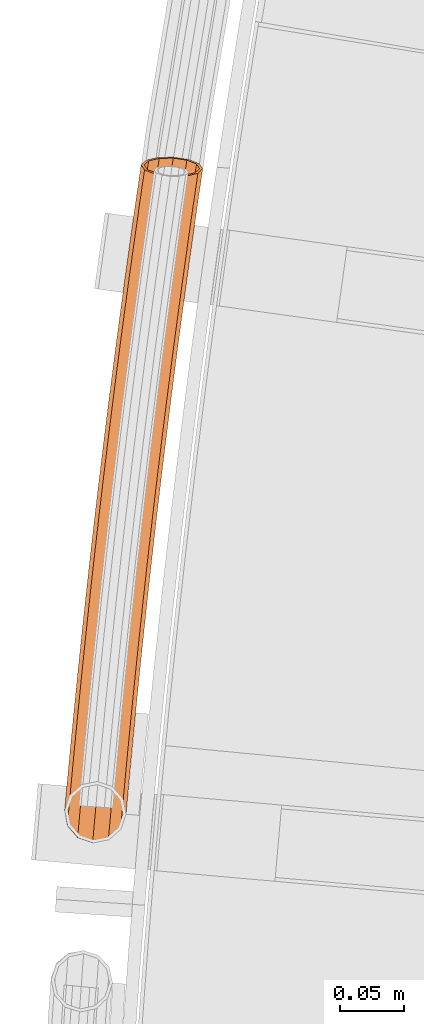
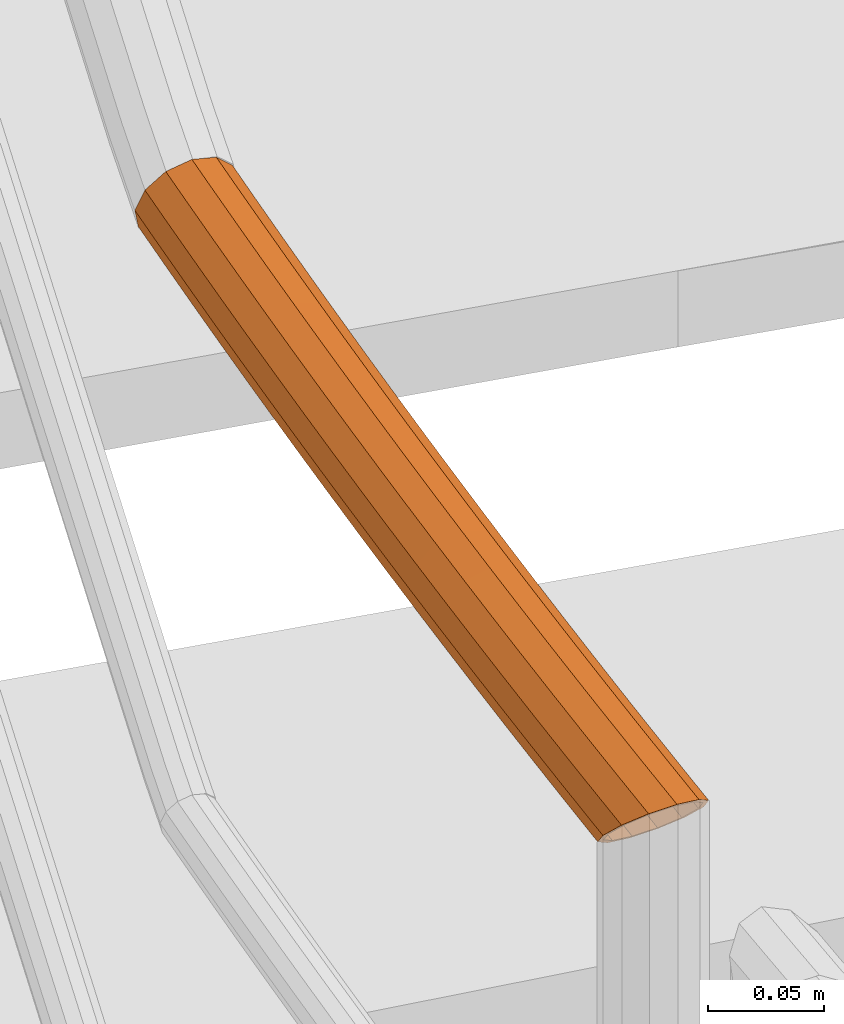
# One storey, part 58 of 126: 1 proxy.
"""IFC2X3 building model written with IfcOpenShell, lengths in millimetres."""

import ifcopenshell
import ifcopenshell.guid

model = None  # the IFC model being written
_history = None  # IfcOwnerHistory: only IFC2X3 demands one
_inside = {}  # id of a spatial element -> (the spatial element, [elements in it])
_under = {}  # id of a project, library or spatial element -> (it, [spatial elements below it])
_declared = {}  # id of a project -> (the project, [libraries it declares])
_typed = {}  # id of a type object -> (the type object, [elements of that type])
_made_of = {}  # id of a material, layer set ... -> (it, [elements and type objects made of it])


def new_model(schema):
    """Start an empty IFC model of exactly this schema.

    Asked for "IFC4X3", IfcOpenShell would pick the latest addendum, in which some entities
    have other attributes; the version numbers below select the first issue.
    IFC2X3 requires an IfcOwnerHistory on every rooted entity: one is made here for all.
    """
    global model, _history
    if schema == "IFC4X3":
        model = ifcopenshell.file(schema_version=(4, 3, 0, 0))
    else:
        model = ifcopenshell.file(schema=schema)
    _inside.clear()
    _under.clear()
    _declared.clear()
    _typed.clear()
    _made_of.clear()
    _history = None
    if model.schema == "IFC2X3":
        org = make("IfcOrganization", Name="unknown")
        user = make(
            "IfcPersonAndOrganization",
            ThePerson=make("IfcPerson", FamilyName="unknown"),
            TheOrganization=org,
        )
        app = make(
            "IfcApplication",
            ApplicationDeveloper=org,
            Version="unknown",
            ApplicationFullName="unknown",
            ApplicationIdentifier="unknown",
        )
        _history = make(
            "IfcOwnerHistory",
            OwningUser=user,
            OwningApplication=app,
            ChangeAction="ADDED",
            CreationDate=0,
        )
    return model


def make(cls, **values):
    """One entity of the class cls with the attributes given. An attribute that is None is left unset."""
    return model.create_entity(
        cls, **{name: value for name, value in values.items() if value is not None}
    )


def rooted(cls, **values):
    """An entity with a GlobalId (a new one), such as an element, a storey or a relation."""
    return make(cls, GlobalId=ifcopenshell.guid.new(), OwnerHistory=_history, **values)


def si_unit(unit_type, name, prefix=None):
    """IfcSIUnit, for example si_unit("LENGTHUNIT", "METRE", prefix="MILLI")."""
    return make("IfcSIUnit", UnitType=unit_type, Prefix=prefix, Name=name)


def assignment(units):
    """IfcUnitAssignment: the units of a project."""
    return None if units is None else make("IfcUnitAssignment", Units=units)


def point(xyz):
    """IfcCartesianPoint."""
    return None if xyz is None else make("IfcCartesianPoint", Coordinates=xyz)


def direction(xyz):
    """IfcDirection."""
    return None if xyz is None else make("IfcDirection", DirectionRatios=xyz)


def frame(location, z_axis=None, x_axis=None):
    """IfcAxis2Placement3D, a coordinate frame: its origin and axes. An axis left out is left unset."""
    return make(
        "IfcAxis2Placement3D",
        Location=point(location),
        Axis=direction(z_axis),
        RefDirection=direction(x_axis),
    )


def origin():
    """The frame at (0, 0, 0) with its axes left unset."""
    return frame((0.0, 0.0, 0.0))


def origin_with_axes():
    """The frame at (0, 0, 0) with the z axis (0, 0, 1) and the x axis (1, 0, 0) written out."""
    return frame((0.0, 0.0, 0.0), z_axis=(0.0, 0.0, 1.0), x_axis=(1.0, 0.0, 0.0))


def place(relative_to, where):
    """IfcLocalPlacement: puts the frame where relative to a parent placement (None: the world)."""
    return make(
        "IfcLocalPlacement", PlacementRelTo=relative_to, RelativePlacement=where
    )


def context(
    kind, dimensions, precision=None, world=None, true_north=None, identifier=None
):
    """IfcGeometricRepresentationContext, for example the 3D "Model" context."""
    return make(
        "IfcGeometricRepresentationContext",
        ContextIdentifier=identifier,
        ContextType=kind,
        CoordinateSpaceDimension=dimensions,
        Precision=precision,
        WorldCoordinateSystem=world,
        TrueNorth=true_north,
    )


def project(units=None, contexts=None):
    """IfcProject with its units and contexts."""
    return rooted(
        "IfcProject",
        Name="project",
        RepresentationContexts=contexts,
        UnitsInContext=assignment(units),
    )


def spatial(cls, under=None, at=None, **own):
    """A site, building, storey or space (cls), placed at a placement, below another one or the project."""
    s = rooted(cls, ObjectPlacement=at, **own)
    if under is not None:
        _under.setdefault(under.id(), (under, []))[1].append(s)
    return s


def faces_of(points, faces, orient=None, outer=None):
    """IfcFace entities. A face is a list of loops; a loop is a list of indices into points, from 0.

    orient and outer hold one flag for each loop. By default every Orientation is true, the
    first loop of a face is its IfcFaceOuterBound and the others are IfcFaceBound.
    """
    made = []
    for i, loops in enumerate(faces):
        bounds = []
        for j, loop in enumerate(loops):
            is_outer = j == 0 if outer is None else outer[i][j]
            bounds.append(
                make(
                    "IfcFaceOuterBound" if is_outer else "IfcFaceBound",
                    Bound=make("IfcPolyLoop", Polygon=[points[k] for k in loop]),
                    Orientation=True if orient is None else orient[i][j],
                )
            )
        made.append(make("IfcFace", Bounds=bounds))
    return made


def faceted_brep(points, faces, orient=None, outer=None, voids=None):
    """IfcFacetedBrep: a solid bounded by flat faces; with voids (closed shells), ...WithVoids."""
    shared = [point(p) for p in points]
    hull = make("IfcClosedShell", CfsFaces=faces_of(shared, faces, orient, outer))
    if voids is None:
        return make("IfcFacetedBrep", Outer=hull)
    return make(
        "IfcFacetedBrepWithVoids",
        Outer=hull,
        Voids=[
            make(cls, CfsFaces=faces_of(shared, fs, o, b)) for cls, fs, o, b in voids
        ],
    )


def shape(context_of_items, identifier, shape_type, items):
    """IfcShapeRepresentation: the items that make up one representation, for example the "Body"."""
    return make(
        "IfcShapeRepresentation",
        ContextOfItems=context_of_items,
        RepresentationIdentifier=identifier,
        RepresentationType=shape_type,
        Items=items,
    )


def material(Name=None, Category=None):
    """IfcMaterial."""
    return make("IfcMaterial", Name=Name, Category=Category)


def made_of(thing, what):
    """Note that an element or type object is made of a material, layer set ...; save() writes the relation."""
    if what is not None:
        _made_of.setdefault(what.id(), (what, []))[1].append(thing)
    return thing


def element(
    cls,
    number,
    at=None,
    inside=None,
    cuts=None,
    type_object=None,
    material=None,
    context=None,
    identifier="Body",
    shape_type=None,
    held_by="IfcProductDefinitionShape",
    body=None,
    shapes=None,
    **own,
):
    """One element of the class cls, such as IfcWall. Its Tag is "e" and its number.

    at: its placement. inside: the storey or other place that contains it. cuts: it is an
    opening in that element (IfcRelVoidsElement). A single representation is given by context,
    identifier, shape_type and body (its items); several are given by shapes. held_by: the class
    of the entity that holds the representations. save() writes the other relations.
    """
    e = rooted(cls, Tag="e%d" % number, ObjectPlacement=at, **own)
    if body is not None:
        shapes = [shape(context, identifier, shape_type, body)]
    if shapes is not None:
        e.Representation = make(held_by, Representations=shapes)
    if inside is not None:
        _inside.setdefault(inside.id(), (inside, []))[1].append(e)
    if cuts is not None:
        rooted(
            "IfcRelVoidsElement", RelatingBuildingElement=cuts, RelatedOpeningElement=e
        )
    if type_object is not None:
        _typed.setdefault(type_object.id(), (type_object, []))[1].append(e)
    return made_of(e, material)


def aggregate(whole, parts):
    """IfcRelAggregates: a whole, such as a stair, and the parts it consists of."""
    return rooted("IfcRelAggregates", RelatingObject=whole, RelatedObjects=parts)


def save(model, path):
    """Write the relations noted so far, then the file.

    IfcRelAggregates (storeys below a building ...), IfcRelContainedInSpatialStructure (elements
    in a storey), IfcRelDefinesByType, IfcRelAssociatesMaterial and IfcRelDeclares: one each for
    every whole, place, type object, material and project.
    """
    for whole, parts in _under.values():
        aggregate(whole, parts)
    for where, things in _inside.values():
        rooted(
            "IfcRelContainedInSpatialStructure",
            RelatedElements=things,
            RelatingStructure=where,
        )
    for kind, things in _typed.values():
        rooted("IfcRelDefinesByType", RelatedObjects=things, RelatingType=kind)
    for what, things in _made_of.values():
        rooted("IfcRelAssociatesMaterial", RelatedObjects=things, RelatingMaterial=what)
    for by, libraries in _declared.values():
        rooted("IfcRelDeclares", RelatingContext=by, RelatedDefinitions=libraries)
    model.write(path)


model = new_model("IFC2X3")

# Units and contexts
context_of_model_1 = context(None, 3, precision=0.1, world=origin())
context_of_model_2 = context(None, 3, precision=0.1, world=origin())
ifc_project = project(units=[si_unit("LENGTHUNIT", "METRE", prefix="MILLI"), si_unit("AREAUNIT", "SQUARE_METRE", prefix="CENTI"), si_unit("VOLUMEUNIT", "CUBIC_METRE", prefix="CENTI"), si_unit("MASSUNIT", "GRAM", prefix="KILO")], contexts=[context_of_model_1, context_of_model_2])

# Site, building, storey
site_placement = place(None, origin_with_axes())
site = spatial("IfcSite", under=ifc_project, at=site_placement, CompositionType="ELEMENT")
building_placement = place(site_placement, origin_with_axes())
building = spatial("IfcBuilding", under=site, at=building_placement, CompositionType="ELEMENT")
storey_placement = place(building_placement, origin_with_axes())
storey = spatial("IfcBuildingStorey", under=building, at=storey_placement, CompositionType="ELEMENT")

# Proxy
ifc_material = material(Name="S235JRG2")
proxy_placement = place(storey_placement, origin_with_axes())
element("IfcBuildingElementProxy", 1, at=proxy_placement, inside=storey, material=ifc_material, Name="HANDLAUF", context=context_of_model_2, shape_type="Brep", body=[
    faceted_brep([(-812.9843, 8779.5754, 6639.3145), (-813.4282, 8774.4188, 6639.3145), (-807.944, 8779.1326, 6634.2548), (-825.013, 8780.632, 6642.55), (-825.758, 8771.9781, 6642.55), (-837.0417, 8781.6886, 6639.3145), (-837.5326, 8775.986, 6639.3145), (-842.8746, 8782.2009, 6633.4592), (-835.7965, 8781.5792, 6637.1494), (-836.0993, 8778.0624, 6637.1494), (-839.3936, 8781.8952, 6633.5385), (-825.013, 8780.632, 6640.05), (-825.5435, 8774.4694, 6640.05), (-814.2296, 8779.6848, 6637.1494), (-814.4901, 8776.6574, 6637.1494), (-811.2705, 8779.4248, 6634.179), (-846.3017, 8813.6469, 6618.4), (-843.0796, 8813.3526, 6606.325), (-843.4312, 8809.4287, 6606.325), (-847.7387, 8797.6082, 6618.4), (-839.2575, 8813.0034, 6602.487), (-801.424, 8809.5469, 6606.325), (-801.6778, 8806.714, 6606.325), (-804.3318, 8809.8126, 6603.4051), (-798.2019, 8809.2526, 6618.4), (-799.5261, 8794.4736, 6618.4), (-801.424, 8809.5469, 6630.475), (-803.8337, 8782.6531, 6630.475), (-810.2268, 8810.3512, 6639.3145), (-822.2518, 8811.4498, 6642.55), (-834.2767, 8812.5483, 6639.3145), (-845.587, 8785.3678, 6630.475), (-843.0796, 8813.3526, 6630.475), (-843.812, 8813.4195, 6618.4), (-840.9235, 8813.1556, 6629.225), (-843.3143, 8786.4727, 6629.225), (-845.2432, 8797.446, 6618.4), (-833.0319, 8812.4346, 6637.1494), (-822.2518, 8811.4498, 6640.05), (-811.4717, 8810.4649, 6637.1494), (-803.5801, 8809.7439, 6629.225), (-805.8832, 8784.039, 6629.225), (-800.6915, 8809.48, 6618.4), (-802.0216, 8794.6358, 6618.4), (-803.5801, 8809.7439, 6607.575), (-803.9505, 8805.6091, 6607.575), (-807.8241, 8810.1317, 6603.3133), (-840.9235, 8813.1556, 6607.575), (-841.3816, 8808.0428, 6607.575), (-835.9434, 8812.7006, 6602.5741), (-843.425, 8844.5388, 6618.4), (-840.204, 8844.2332, 6606.325), (-831.404, 8843.3983, 6597.4855), (-833.8007, 8817.6607, 6597.4855), (-819.383, 8842.2577, 6594.25), (-821.4463, 8820.0997, 6594.25), (-807.3619, 8841.1171, 6597.4855), (-809.6922, 8816.0932, 6597.4855), (-798.5619, 8840.2822, 6606.325), (-795.3409, 8839.9766, 6618.4), (-798.5619, 8840.2822, 6630.475), (-807.3619, 8841.1171, 6639.3145), (-819.383, 8842.2577, 6642.55), (-831.404, 8843.3983, 6639.3145), (-840.204, 8844.2332, 6630.475), (-840.9362, 8844.3027, 6618.4), (-838.0486, 8844.0287, 6629.225), (-830.1596, 8843.2802, 6637.1494), (-819.383, 8842.2577, 6640.05), (-808.6064, 8841.2352, 6637.1494), (-800.7173, 8840.4867, 6629.225), (-797.8297, 8840.2127, 6618.4), (-800.7173, 8840.4867, 6607.575), (-811.1408, 8814.0178, 6599.6506), (-808.6064, 8841.2352, 6599.6506), (-819.383, 8842.2577, 6596.75), (-821.6782, 8817.6095, 6596.75), (-830.1596, 8843.2802, 6599.6506), (-832.7536, 8815.423, 6599.6506), (-838.0486, 8844.0287, 6607.575), (-840.4406, 8875.4205, 6618.4), (-837.2207, 8875.1036, 6606.325), (-828.4236, 8874.238, 6597.4855), (-816.4066, 8873.0554, 6594.25), (-804.3897, 8871.8729, 6597.4855), (-795.5926, 8871.0073, 6606.325), (-792.3727, 8870.6904, 6618.4), (-795.5926, 8871.0073, 6630.475), (-804.3897, 8871.8729, 6639.3145), (-816.4066, 8873.0554, 6642.55), (-828.4236, 8874.238, 6639.3145), (-837.2207, 8875.1036, 6630.475), (-837.9526, 8875.1756, 6618.4), (-835.066, 8874.8916, 6629.225), (-827.1796, 8874.1155, 6637.1494), (-816.4066, 8873.0554, 6640.05), (-805.6337, 8871.9953, 6637.1494), (-797.7473, 8871.2193, 6629.225), (-794.8607, 8870.9353, 6618.4), (-797.7473, 8871.2193, 6607.575), (-805.6337, 8871.9953, 6599.6506), (-816.4066, 8873.0554, 6596.75), (-827.1796, 8874.1155, 6599.6506), (-835.066, 8874.8916, 6607.575), (-837.3484, 8906.2915, 6618.4), (-834.1296, 8905.9634, 6606.325), (-825.3356, 8905.0671, 6597.4855), (-813.3228, 8903.8426, 6594.25), (-801.31, 8902.6182, 6597.4855), (-792.5161, 8901.7218, 6606.325), (-789.2973, 8901.3937, 6618.4), (-792.5161, 8901.7218, 6630.475), (-801.31, 8902.6182, 6639.3145), (-813.3228, 8903.8426, 6642.55), (-825.3356, 8905.0671, 6639.3145), (-834.1296, 8905.9634, 6630.475), (-834.8613, 8906.038, 6618.4), (-831.9756, 8905.7439, 6629.225), (-824.092, 8904.9403, 6637.1494), (-813.3228, 8903.8426, 6640.05), (-802.5536, 8902.7449, 6637.1494), (-794.67, 8901.9413, 6629.225), (-791.7844, 8901.6472, 6618.4), (-794.67, 8901.9413, 6607.575), (-802.5536, 8902.7449, 6599.6506), (-813.3228, 8903.8426, 6596.75), (-824.092, 8904.9403, 6599.6506), (-831.9756, 8905.7439, 6607.575), (-834.1484, 8937.1516, 6618.4), (-830.9308, 8936.8123, 6606.325), (-822.14, 8935.8852, 6597.4855), (-810.1315, 8934.6188, 6594.25), (-798.1231, 8933.3525, 6597.4855), (-789.3323, 8932.4254, 6606.325), (-786.1147, 8932.0861, 6618.4), (-789.3323, 8932.4254, 6630.475), (-798.1231, 8933.3525, 6639.3145), (-810.1315, 8934.6188, 6642.55), (-822.14, 8935.8852, 6639.3145), (-830.9308, 8936.8123, 6630.475), (-831.6622, 8936.8894, 6618.4), (-828.7776, 8936.5852, 6629.225), (-820.8969, 8935.7541, 6637.1494), (-810.1315, 8934.6188, 6640.05), (-799.3662, 8933.4835, 6637.1494), (-791.4855, 8932.6525, 6629.225), (-788.6009, 8932.3483, 6618.4), (-791.4855, 8932.6525, 6607.575), (-799.3662, 8933.4835, 6599.6506), (-810.1315, 8934.6188, 6596.75), (-820.8969, 8935.7541, 6599.6506), (-828.7776, 8936.5852, 6607.575), (-830.8407, 8968.0003, 6618.4), (-827.6243, 8967.6497, 6606.325), (-818.8368, 8966.692, 6597.4855), (-806.8329, 8965.3837, 6594.25), (-794.8289, 8964.0754, 6597.4855), (-786.0414, 8963.1177, 6606.325), (-782.825, 8962.7671, 6618.4), (-786.0414, 8963.1177, 6630.475), (-794.8289, 8964.0754, 6639.3145), (-806.8329, 8965.3837, 6642.55), (-818.8368, 8966.692, 6639.3145), (-827.6243, 8967.6497, 6630.475), (-828.3554, 8967.7294, 6618.4), (-825.472, 8967.4152, 6629.225), (-817.5942, 8966.5566, 6637.1494), (-806.8329, 8965.3837, 6640.05), (-796.0716, 8964.2109, 6637.1494), (-788.1938, 8963.3523, 6629.225), (-785.3103, 8963.038, 6618.4), (-788.1938, 8963.3523, 6607.575), (-796.0716, 8964.2109, 6599.6506), (-806.8329, 8965.3837, 6596.75), (-817.5942, 8966.5566, 6599.6506), (-825.472, 8967.4152, 6607.575), (-827.4254, 8998.8373, 6618.4), (-824.2102, 8998.4755, 6606.325), (-815.4261, 8997.4871, 6597.4855), (-803.4268, 8996.1369, 6594.25), (-791.4275, 8994.7867, 6597.4855), (-782.6434, 8993.7983, 6606.325), (-779.4282, 8993.4365, 6618.4), (-782.6434, 8993.7983, 6630.475), (-791.4275, 8994.7867, 6639.3145), (-803.4268, 8996.1369, 6642.55), (-815.4261, 8997.4871, 6639.3145), (-824.2102, 8998.4755, 6630.475), (-824.9411, 8998.5577, 6618.4), (-822.0587, 8998.2334, 6629.225), (-814.1839, 8997.3473, 6637.1494), (-803.4268, 8996.1369, 6640.05), (-792.6697, 8994.9265, 6637.1494), (-784.7949, 8994.0404, 6629.225), (-781.9126, 8993.7161, 6618.4), (-784.7949, 8994.0404, 6607.575), (-792.6697, 8994.9265, 6599.6506), (-803.4268, 8996.1369, 6596.75), (-814.1839, 8997.3473, 6599.6506), (-822.0587, 8998.2334, 6607.575), (-823.9025, 9029.6621, 6618.4), (-820.6885, 9029.2891, 6606.325), (-811.9079, 9028.2701, 6597.4855), (-799.9134, 9026.878, 6594.25), (-787.9189, 9025.486, 6597.4855), (-779.1383, 9024.4669, 6606.325), (-775.9244, 9024.0939, 6618.4), (-779.1383, 9024.4669, 6630.475), (-787.9189, 9025.486, 6639.3145), (-799.9134, 9026.878, 6642.55), (-811.9079, 9028.2701, 6639.3145), (-820.6885, 9029.2891, 6630.475), (-821.4191, 9029.3739, 6618.4), (-818.5379, 9029.0395, 6629.225), (-810.6663, 9028.126, 6637.1494), (-799.9134, 9026.878, 6640.05), (-789.1606, 9025.6301, 6637.1494), (-781.289, 9024.7165, 6629.225), (-778.4078, 9024.3821, 6618.4), (-781.289, 9024.7165, 6607.575), (-789.1606, 9025.6301, 6599.6506), (-799.9134, 9026.878, 6596.75), (-810.6663, 9028.126, 6599.6506), (-818.5379, 9029.0395, 6607.575), (-820.2719, 9060.4745, 6618.4), (-817.0593, 9060.0903, 6606.325), (-808.2824, 9059.0406, 6597.4855), (-796.2928, 9057.6067, 6594.25), (-784.3032, 9056.1728, 6597.4855), (-775.5262, 9055.1231, 6606.325), (-772.3136, 9054.7388, 6618.4), (-775.5262, 9055.1231, 6630.475), (-784.3032, 9056.1728, 6639.3145), (-796.2928, 9057.6067, 6642.55), (-808.2824, 9059.0406, 6639.3145), (-817.0593, 9060.0903, 6630.475), (-817.7896, 9060.1776, 6618.4), (-814.9096, 9059.8332, 6629.225), (-807.0412, 9058.8921, 6637.1494), (-796.2928, 9057.6067, 6640.05), (-785.5444, 9056.3212, 6637.1494), (-777.676, 9055.3802, 6629.225), (-774.7959, 9055.0357, 6618.4), (-777.676, 9055.3802, 6607.575), (-785.5444, 9056.3212, 6599.6506), (-796.2928, 9057.6067, 6596.75), (-807.0412, 9058.8921, 6599.6506), (-814.9096, 9059.8332, 6607.575), (-816.5339, 9091.274, 6618.4), (-813.3226, 9090.8786, 6606.325), (-804.5494, 9089.7983, 6597.4855), (-792.5649, 9088.3225, 6594.25), (-780.5804, 9086.8467, 6597.4855), (-771.8071, 9085.7664, 6606.325), (-768.5959, 9085.371, 6618.4), (-771.8071, 9085.7664, 6630.475), (-780.5804, 9086.8467, 6639.3145), (-792.5649, 9088.3225, 6642.55), (-804.5494, 9089.7983, 6639.3145), (-813.3226, 9090.8786, 6630.475), (-814.0526, 9090.9685, 6618.4), (-811.1738, 9090.614, 6629.225), (-803.3087, 9089.6455, 6637.1494), (-792.5649, 9088.3225, 6640.05), (-781.821, 9086.9995, 6637.1494), (-773.9559, 9086.031, 6629.225), (-771.0771, 9085.6765, 6618.4), (-773.9559, 9086.031, 6607.575), (-781.821, 9086.9995, 6599.6506), (-792.5649, 9088.3225, 6596.75), (-803.3087, 9089.6455, 6599.6506), (-811.1738, 9090.614, 6607.575), (-812.6883, 9122.0603, 6618.4), (-809.4785, 9121.6537, 6606.325), (-800.709, 9120.5427, 6597.4855), (-788.7298, 9119.0251, 6594.25), (-776.7505, 9117.5076, 6597.4855), (-767.9811, 9116.3966, 6606.325), (-764.7712, 9115.99, 6618.4), (-767.9811, 9116.3966, 6630.475), (-776.7505, 9117.5076, 6639.3145), (-788.7298, 9119.0251, 6642.55), (-800.709, 9120.5427, 6639.3145), (-809.4785, 9121.6537, 6630.475), (-810.2081, 9121.7461, 6618.4), (-807.3306, 9121.3816, 6629.225), (-799.469, 9120.3856, 6637.1494), (-788.7298, 9119.0251, 6640.05), (-777.9906, 9117.6646, 6637.1494), (-770.129, 9116.6687, 6629.225), (-767.2514, 9116.3042, 6618.4), (-770.129, 9116.6687, 6607.575), (-777.9906, 9117.6646, 6599.6506), (-788.7298, 9119.0251, 6596.75), (-799.469, 9120.3856, 6599.6506), (-807.3306, 9121.3816, 6607.575), (-808.7353, 9152.833, 6618.4), (-805.5269, 9152.4151, 6606.325), (-796.7614, 9151.2736, 6597.4855), (-784.7875, 9149.7142, 6594.25), (-772.8136, 9148.1548, 6597.4855), (-764.0481, 9147.0133, 6606.325), (-760.8397, 9146.5954, 6618.4), (-764.0481, 9147.0133, 6630.475), (-772.8136, 9148.1548, 6639.3145), (-784.7875, 9149.7142, 6642.55), (-796.7614, 9151.2736, 6639.3145), (-805.5269, 9152.4151, 6630.475), (-806.2563, 9152.5101, 6618.4), (-803.38, 9152.1355, 6629.225), (-795.5219, 9151.1122, 6637.1494), (-784.7875, 9149.7142, 6640.05), (-774.0532, 9148.3162, 6637.1494), (-766.1951, 9147.2929, 6629.225), (-763.3188, 9146.9183, 6618.4), (-766.1951, 9147.2929, 6607.575), (-774.0532, 9148.3162, 6599.6506), (-784.7875, 9149.7142, 6596.75), (-795.5219, 9151.1122, 6599.6506), (-803.38, 9152.1355, 6607.575), (-804.675, 9183.5917, 6618.4), (-801.468, 9183.1626, 6606.325), (-792.7066, 9181.9905, 6597.4855), (-780.7382, 9180.3893, 6594.25), (-768.7698, 9178.7881, 6597.4855), (-760.0083, 9177.616, 6606.325), (-756.8014, 9177.1869, 6618.4), (-760.0083, 9177.616, 6630.475), (-768.7698, 9178.7881, 6639.3145), (-780.7382, 9180.3893, 6642.55), (-792.7066, 9181.9905, 6639.3145), (-801.468, 9183.1626, 6630.475), (-802.197, 9183.2601, 6618.4), (-799.3221, 9182.8755, 6629.225), (-791.4676, 9181.8247, 6637.1494), (-780.7382, 9180.3893, 6640.05), (-770.0088, 9178.9539, 6637.1494), (-762.1543, 9177.9031, 6629.225), (-759.2793, 9177.5185, 6618.4), (-762.1543, 9177.9031, 6607.575), (-770.0088, 9178.9539, 6599.6506), (-780.7382, 9180.3893, 6596.75), (-791.4676, 9181.8247, 6599.6506), (-799.3221, 9182.8755, 6607.575), (-800.5072, 9214.336, 6618.4), (-797.3018, 9213.8958, 6606.325), (-788.5445, 9212.693, 6597.4855), (-776.5818, 9211.0501, 6594.25), (-764.6191, 9209.4071, 6597.4855), (-755.8617, 9208.2044, 6606.325), (-752.6563, 9207.7642, 6618.4), (-755.8617, 9208.2044, 6630.475), (-764.6191, 9209.4071, 6639.3145), (-776.5818, 9211.0501, 6642.55), (-788.5445, 9212.693, 6639.3145), (-797.3018, 9213.8958, 6630.475), (-798.0305, 9213.9958, 6618.4), (-795.1569, 9213.6012, 6629.225), (-787.3061, 9212.523, 6637.1494), (-776.5818, 9211.0501, 6640.05), (-765.8574, 9209.5772, 6637.1494), (-758.0067, 9208.499, 6629.225), (-755.1331, 9208.1044, 6618.4), (-758.0067, 9208.499, 6607.575), (-765.8574, 9209.5772, 6599.6506), (-776.5818, 9211.0501, 6596.75), (-787.3061, 9212.523, 6599.6506), (-795.1569, 9213.6012, 6607.575), (-796.2322, 9245.0656, 6618.4), (-793.0284, 9244.6142, 6606.325), (-784.2753, 9243.3809, 6597.4855), (-772.3184, 9241.6962, 6594.25), (-760.3615, 9240.0115, 6597.4855), (-751.6084, 9238.7782, 6606.325), (-748.4045, 9238.3268, 6618.4), (-751.6084, 9238.7782, 6630.475), (-760.3615, 9240.0115, 6639.3145), (-772.3184, 9241.6962, 6642.55), (-784.2753, 9243.3809, 6639.3145), (-793.0284, 9244.6142, 6630.475), (-793.7567, 9244.7168, 6618.4), (-790.8845, 9244.3121, 6629.225), (-783.0375, 9243.2065, 6637.1494), (-772.3184, 9241.6962, 6640.05), (-761.5992, 9240.1859, 6637.1494), (-753.7523, 9239.0803, 6629.225), (-750.8801, 9238.6756, 6618.4), (-753.7523, 9239.0803, 6607.575), (-761.5992, 9240.1859, 6599.6506), (-772.3184, 9241.6962, 6596.75), (-783.0375, 9243.2065, 6599.6506), (-790.8845, 9244.3121, 6607.575), (-791.85, 9275.78, 6618.4), (-788.6477, 9275.3175, 6606.325), (-779.899, 9274.0536, 6597.4855), (-767.948, 9272.3272, 6594.25), (-755.9971, 9270.6008, 6597.4855), (-747.2484, 9269.337, 6606.325), (-744.0461, 9268.8744, 6618.4), (-747.2484, 9269.337, 6630.475), (-755.9971, 9270.6008, 6639.3145), (-767.948, 9272.3272, 6642.55), (-779.899, 9274.0536, 6639.3145), (-788.6477, 9275.3175, 6630.475), (-789.3756, 9275.4226, 6618.4), (-786.5049, 9275.0079, 6629.225), (-778.6618, 9273.8749, 6637.1494), (-767.948, 9272.3272, 6640.05), (-757.2342, 9270.7795, 6637.1494), (-749.3912, 9269.6465, 6629.225), (-746.5204, 9269.2318, 6618.4), (-749.3912, 9269.6465, 6607.575), (-757.2342, 9270.7795, 6599.6506), (-767.948, 9272.3272, 6596.75), (-778.6618, 9273.8749, 6599.6506), (-786.5049, 9275.0079, 6607.575), (-787.7121, 9304.0751, 6618.4), (-785.4627, 9306.1981, 6611.2402), (-784.1599, 9306.0053, 6606.325), (-775.4156, 9304.7109, 6597.4855), (-763.4708, 9302.9428, 6594.25), (-751.5259, 9301.1747, 6597.4855), (-742.7817, 9299.8803, 6606.325), (-739.5811, 9299.4065, 6618.4), (-740.7847, 9299.5847, 6622.9409), (-743.1516, 9297.3507, 6630.475), (-752.4069, 9295.1507, 6639.3145), (-764.6439, 9294.9209, 6642.55), (-776.5839, 9296.7227, 6639.3145), (-785.0274, 9300.0733, 6630.475), (-785.2093, 9303.9123, 6618.4), (-782.8025, 9300.3249, 6629.225), (-775.233, 9297.3211, 6637.1494), (-764.5291, 9295.7058, 6640.05), (-753.5588, 9295.9119, 6637.1494), (-745.2617, 9297.8841, 6629.225), (-743.0972, 9299.927, 6622.3353), (-742.0541, 9299.7726, 6618.4), (-744.9234, 9300.1973, 6607.575), (-752.7624, 9301.3577, 6599.6506), (-763.4708, 9302.9428, 6596.75), (-774.1791, 9304.5279, 6599.6506), (-782.0182, 9305.6882, 6607.575), (-783.1502, 9305.8558, 6611.8458), (-783.9127, 9307.6552, 6606.325), (-774.6451, 9309.8543, 6597.4855), (-762.401, 9310.0837, 6594.25), (-750.4612, 9308.282, 6597.4855), (-742.0249, 9304.9318, 6606.325), (-739.3527, 9300.9309, 6618.4), (-741.8562, 9301.0936, 6618.4), (-744.2518, 9304.6804, 6607.575), (-751.8148, 9307.6837, 6599.6506), (-762.5186, 9309.299, 6596.75), (-773.4952, 9309.0933, 6599.6506), (-781.8034, 9307.1219, 6607.575)], [[[0, 1, 2]], [[0, 3, 4, 1]], [[3, 5, 6, 4]], [[5, 7, 6]], [[8, 9, 10]], [[8, 11, 12, 9]], [[11, 13, 14, 12]], [[13, 15, 14]], [[16, 17, 18, 19]], [[17, 20, 18]], [[21, 22, 23]], [[21, 24, 25, 22]], [[24, 26, 27, 25]], [[0, 2, 27, 26, 28]], [[0, 28, 29, 3]], [[3, 29, 30, 5]], [[31, 7, 5, 30, 32]], [[16, 19, 31, 32]], [[33, 34, 35, 36]], [[35, 34, 37, 8, 10]], [[8, 37, 38, 11]], [[11, 38, 39, 13]], [[13, 39, 40, 41, 15]], [[40, 42, 43, 41]], [[42, 44, 45, 43]], [[44, 46, 45]], [[47, 48, 49]], [[33, 36, 48, 47]], [[16, 50, 51, 17]], [[17, 51, 52, 53, 20]], [[52, 54, 55, 53]], [[54, 56, 57, 55]], [[57, 56, 58, 21, 23]], [[21, 58, 59, 24]], [[24, 59, 60, 26]], [[26, 60, 61, 28]], [[28, 61, 62, 29]], [[29, 62, 63, 30]], [[30, 63, 64, 32]], [[32, 64, 50, 16]], [[33, 65, 66, 34]], [[34, 66, 67, 37]], [[37, 67, 68, 38]], [[38, 68, 69, 39]], [[39, 69, 70, 40]], [[40, 70, 71, 42]], [[42, 71, 72, 44]], [[73, 46, 44, 72, 74]], [[74, 75, 76, 73]], [[75, 77, 78, 76]], [[47, 49, 78, 77, 79]], [[47, 79, 65, 33]], [[50, 80, 81, 51]], [[51, 81, 82, 52]], [[52, 82, 83, 54]], [[54, 83, 84, 56]], [[56, 84, 85, 58]], [[58, 85, 86, 59]], [[59, 86, 87, 60]], [[60, 87, 88, 61]], [[61, 88, 89, 62]], [[62, 89, 90, 63]], [[63, 90, 91, 64]], [[64, 91, 80, 50]], [[65, 92, 93, 66]], [[66, 93, 94, 67]], [[67, 94, 95, 68]], [[68, 95, 96, 69]], [[69, 96, 97, 70]], [[70, 97, 98, 71]], [[71, 98, 99, 72]], [[72, 99, 100, 74]], [[74, 100, 101, 75]], [[75, 101, 102, 77]], [[77, 102, 103, 79]], [[79, 103, 92, 65]], [[80, 104, 105, 81]], [[81, 105, 106, 82]], [[82, 106, 107, 83]], [[83, 107, 108, 84]], [[84, 108, 109, 85]], [[85, 109, 110, 86]], [[86, 110, 111, 87]], [[87, 111, 112, 88]], [[88, 112, 113, 89]], [[89, 113, 114, 90]], [[90, 114, 115, 91]], [[91, 115, 104, 80]], [[92, 116, 117, 93]], [[93, 117, 118, 94]], [[94, 118, 119, 95]], [[95, 119, 120, 96]], [[96, 120, 121, 97]], [[97, 121, 122, 98]], [[98, 122, 123, 99]], [[99, 123, 124, 100]], [[100, 124, 125, 101]], [[101, 125, 126, 102]], [[102, 126, 127, 103]], [[103, 127, 116, 92]], [[104, 128, 129, 105]], [[105, 129, 130, 106]], [[106, 130, 131, 107]], [[107, 131, 132, 108]], [[108, 132, 133, 109]], [[109, 133, 134, 110]], [[110, 134, 135, 111]], [[111, 135, 136, 112]], [[112, 136, 137, 113]], [[113, 137, 138, 114]], [[114, 138, 139, 115]], [[115, 139, 128, 104]], [[116, 140, 141, 117]], [[117, 141, 142, 118]], [[118, 142, 143, 119]], [[119, 143, 144, 120]], [[120, 144, 145, 121]], [[121, 145, 146, 122]], [[122, 146, 147, 123]], [[123, 147, 148, 124]], [[124, 148, 149, 125]], [[125, 149, 150, 126]], [[126, 150, 151, 127]], [[127, 151, 140, 116]], [[128, 152, 153, 129]], [[129, 153, 154, 130]], [[130, 154, 155, 131]], [[131, 155, 156, 132]], [[132, 156, 157, 133]], [[133, 157, 158, 134]], [[134, 158, 159, 135]], [[135, 159, 160, 136]], [[136, 160, 161, 137]], [[137, 161, 162, 138]], [[138, 162, 163, 139]], [[139, 163, 152, 128]], [[140, 164, 165, 141]], [[141, 165, 166, 142]], [[142, 166, 167, 143]], [[143, 167, 168, 144]], [[144, 168, 169, 145]], [[145, 169, 170, 146]], [[146, 170, 171, 147]], [[147, 171, 172, 148]], [[148, 172, 173, 149]], [[149, 173, 174, 150]], [[150, 174, 175, 151]], [[151, 175, 164, 140]], [[152, 176, 177, 153]], [[153, 177, 178, 154]], [[154, 178, 179, 155]], [[155, 179, 180, 156]], [[156, 180, 181, 157]], [[157, 181, 182, 158]], [[158, 182, 183, 159]], [[159, 183, 184, 160]], [[160, 184, 185, 161]], [[161, 185, 186, 162]], [[162, 186, 187, 163]], [[163, 187, 176, 152]], [[164, 188, 189, 165]], [[165, 189, 190, 166]], [[166, 190, 191, 167]], [[167, 191, 192, 168]], [[168, 192, 193, 169]], [[169, 193, 194, 170]], [[170, 194, 195, 171]], [[171, 195, 196, 172]], [[172, 196, 197, 173]], [[173, 197, 198, 174]], [[174, 198, 199, 175]], [[175, 199, 188, 164]], [[176, 200, 201, 177]], [[177, 201, 202, 178]], [[178, 202, 203, 179]], [[179, 203, 204, 180]], [[180, 204, 205, 181]], [[181, 205, 206, 182]], [[182, 206, 207, 183]], [[183, 207, 208, 184]], [[184, 208, 209, 185]], [[185, 209, 210, 186]], [[186, 210, 211, 187]], [[187, 211, 200, 176]], [[188, 212, 213, 189]], [[189, 213, 214, 190]], [[190, 214, 215, 191]], [[191, 215, 216, 192]], [[192, 216, 217, 193]], [[193, 217, 218, 194]], [[194, 218, 219, 195]], [[195, 219, 220, 196]], [[196, 220, 221, 197]], [[197, 221, 222, 198]], [[198, 222, 223, 199]], [[199, 223, 212, 188]], [[200, 224, 225, 201]], [[201, 225, 226, 202]], [[202, 226, 227, 203]], [[203, 227, 228, 204]], [[204, 228, 229, 205]], [[205, 229, 230, 206]], [[206, 230, 231, 207]], [[207, 231, 232, 208]], [[208, 232, 233, 209]], [[209, 233, 234, 210]], [[210, 234, 235, 211]], [[211, 235, 224, 200]], [[212, 236, 237, 213]], [[213, 237, 238, 214]], [[214, 238, 239, 215]], [[215, 239, 240, 216]], [[216, 240, 241, 217]], [[217, 241, 242, 218]], [[218, 242, 243, 219]], [[219, 243, 244, 220]], [[220, 244, 245, 221]], [[221, 245, 246, 222]], [[222, 246, 247, 223]], [[223, 247, 236, 212]], [[224, 248, 249, 225]], [[225, 249, 250, 226]], [[226, 250, 251, 227]], [[227, 251, 252, 228]], [[228, 252, 253, 229]], [[229, 253, 254, 230]], [[230, 254, 255, 231]], [[231, 255, 256, 232]], [[232, 256, 257, 233]], [[233, 257, 258, 234]], [[234, 258, 259, 235]], [[235, 259, 248, 224]], [[236, 260, 261, 237]], [[237, 261, 262, 238]], [[238, 262, 263, 239]], [[239, 263, 264, 240]], [[240, 264, 265, 241]], [[241, 265, 266, 242]], [[242, 266, 267, 243]], [[243, 267, 268, 244]], [[244, 268, 269, 245]], [[245, 269, 270, 246]], [[246, 270, 271, 247]], [[247, 271, 260, 236]], [[248, 272, 273, 249]], [[249, 273, 274, 250]], [[250, 274, 275, 251]], [[251, 275, 276, 252]], [[252, 276, 277, 253]], [[253, 277, 278, 254]], [[254, 278, 279, 255]], [[255, 279, 280, 256]], [[256, 280, 281, 257]], [[257, 281, 282, 258]], [[258, 282, 283, 259]], [[259, 283, 272, 248]], [[260, 284, 285, 261]], [[261, 285, 286, 262]], [[262, 286, 287, 263]], [[263, 287, 288, 264]], [[264, 288, 289, 265]], [[265, 289, 290, 266]], [[266, 290, 291, 267]], [[267, 291, 292, 268]], [[268, 292, 293, 269]], [[269, 293, 294, 270]], [[270, 294, 295, 271]], [[271, 295, 284, 260]], [[272, 296, 297, 273]], [[273, 297, 298, 274]], [[274, 298, 299, 275]], [[275, 299, 300, 276]], [[276, 300, 301, 277]], [[277, 301, 302, 278]], [[278, 302, 303, 279]], [[279, 303, 304, 280]], [[280, 304, 305, 281]], [[281, 305, 306, 282]], [[282, 306, 307, 283]], [[283, 307, 296, 272]], [[284, 308, 309, 285]], [[285, 309, 310, 286]], [[286, 310, 311, 287]], [[287, 311, 312, 288]], [[288, 312, 313, 289]], [[289, 313, 314, 290]], [[290, 314, 315, 291]], [[291, 315, 316, 292]], [[292, 316, 317, 293]], [[293, 317, 318, 294]], [[294, 318, 319, 295]], [[295, 319, 308, 284]], [[296, 320, 321, 297]], [[297, 321, 322, 298]], [[298, 322, 323, 299]], [[299, 323, 324, 300]], [[300, 324, 325, 301]], [[301, 325, 326, 302]], [[302, 326, 327, 303]], [[303, 327, 328, 304]], [[304, 328, 329, 305]], [[305, 329, 330, 306]], [[306, 330, 331, 307]], [[307, 331, 320, 296]], [[308, 332, 333, 309]], [[309, 333, 334, 310]], [[310, 334, 335, 311]], [[311, 335, 336, 312]], [[312, 336, 337, 313]], [[313, 337, 338, 314]], [[314, 338, 339, 315]], [[315, 339, 340, 316]], [[316, 340, 341, 317]], [[317, 341, 342, 318]], [[318, 342, 343, 319]], [[319, 343, 332, 308]], [[320, 344, 345, 321]], [[321, 345, 346, 322]], [[322, 346, 347, 323]], [[323, 347, 348, 324]], [[324, 348, 349, 325]], [[325, 349, 350, 326]], [[326, 350, 351, 327]], [[327, 351, 352, 328]], [[328, 352, 353, 329]], [[329, 353, 354, 330]], [[330, 354, 355, 331]], [[331, 355, 344, 320]], [[332, 356, 357, 333]], [[333, 357, 358, 334]], [[334, 358, 359, 335]], [[335, 359, 360, 336]], [[336, 360, 361, 337]], [[337, 361, 362, 338]], [[338, 362, 363, 339]], [[339, 363, 364, 340]], [[340, 364, 365, 341]], [[341, 365, 366, 342]], [[342, 366, 367, 343]], [[343, 367, 356, 332]], [[344, 368, 369, 345]], [[345, 369, 370, 346]], [[346, 370, 371, 347]], [[347, 371, 372, 348]], [[348, 372, 373, 349]], [[349, 373, 374, 350]], [[350, 374, 375, 351]], [[351, 375, 376, 352]], [[352, 376, 377, 353]], [[353, 377, 378, 354]], [[354, 378, 379, 355]], [[355, 379, 368, 344]], [[356, 380, 381, 357]], [[357, 381, 382, 358]], [[358, 382, 383, 359]], [[359, 383, 384, 360]], [[360, 384, 385, 361]], [[361, 385, 386, 362]], [[362, 386, 387, 363]], [[363, 387, 388, 364]], [[364, 388, 389, 365]], [[365, 389, 390, 366]], [[366, 390, 391, 367]], [[367, 391, 380, 356]], [[368, 392, 393, 369]], [[369, 393, 394, 370]], [[370, 394, 395, 371]], [[371, 395, 396, 372]], [[372, 396, 397, 373]], [[373, 397, 398, 374]], [[374, 398, 399, 375]], [[375, 399, 400, 376]], [[376, 400, 401, 377]], [[377, 401, 402, 378]], [[378, 402, 403, 379]], [[379, 403, 392, 368]], [[380, 404, 405, 381]], [[381, 405, 406, 382]], [[382, 406, 407, 383]], [[383, 407, 408, 384]], [[384, 408, 409, 385]], [[385, 409, 410, 386]], [[386, 410, 411, 387]], [[387, 411, 412, 388]], [[388, 412, 413, 389]], [[389, 413, 414, 390]], [[390, 414, 415, 391]], [[391, 415, 404, 380]], [[392, 416, 417, 418, 393]], [[393, 418, 419, 394]], [[394, 419, 420, 395]], [[395, 420, 421, 396]], [[396, 421, 422, 397]], [[397, 422, 423, 398]], [[399, 398, 423, 424, 425]], [[399, 425, 426, 400]], [[400, 426, 427, 401]], [[401, 427, 428, 402]], [[402, 428, 429, 403]], [[392, 403, 429, 416]], [[404, 430, 431, 405]], [[405, 431, 432, 406]], [[406, 432, 433, 407]], [[407, 433, 434, 408]], [[408, 434, 435, 409]], [[409, 435, 436, 437, 410]], [[410, 437, 438, 411]], [[411, 438, 439, 412]], [[412, 439, 440, 413]], [[413, 440, 441, 414]], [[414, 441, 442, 415]], [[404, 415, 442, 443, 430]], [[417, 444, 418]], [[418, 444, 445, 419]], [[419, 445, 446, 420]], [[420, 446, 447, 421]], [[421, 447, 448, 422]], [[422, 448, 449, 423]], [[423, 449, 424]], [[436, 450, 437]], [[437, 450, 451, 438]], [[438, 451, 452, 439]], [[439, 452, 453, 440]], [[440, 453, 454, 441]], [[441, 454, 455, 442]], [[442, 455, 443]], [[19, 18, 20, 53, 55, 57, 23, 22, 25, 27, 2, 1, 4, 6, 7, 31], [9, 12, 14, 15, 41, 43, 45, 46, 73, 76, 78, 49, 48, 36, 35, 10]], [[416, 429, 428, 427, 426, 425, 424, 449, 448, 447, 446, 445, 444, 417], [430, 443, 455, 454, 453, 452, 451, 450, 436, 435, 434, 433, 432, 431]]]),
])

save(model, "model.ifc")
